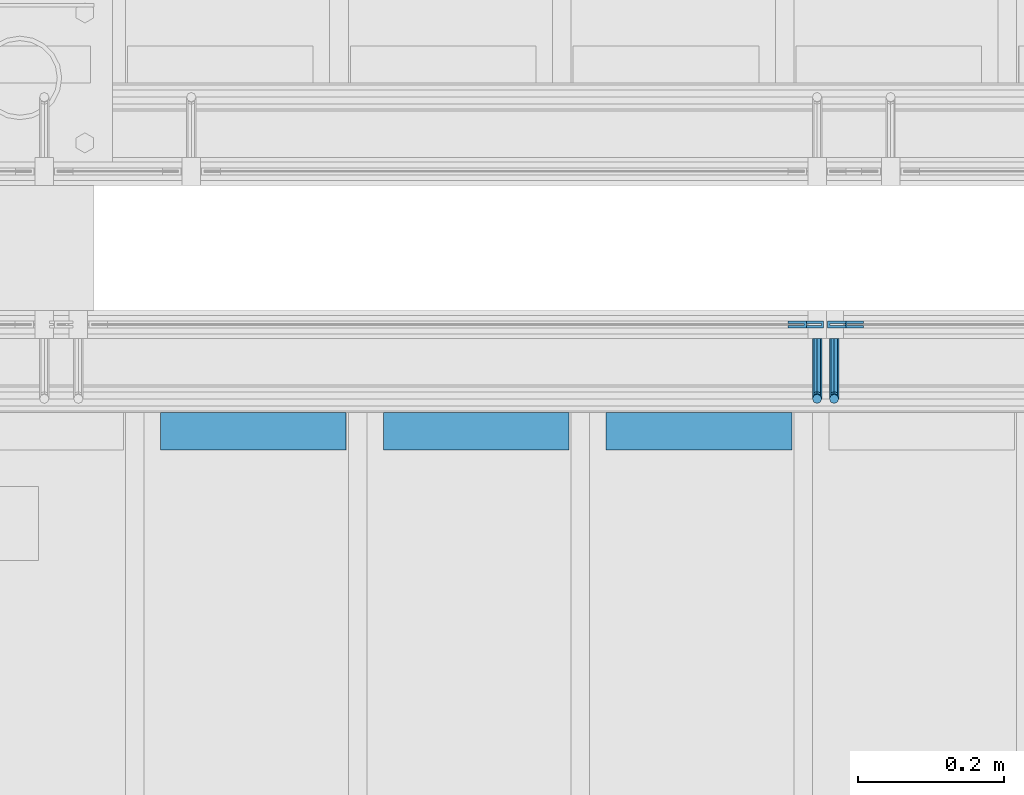
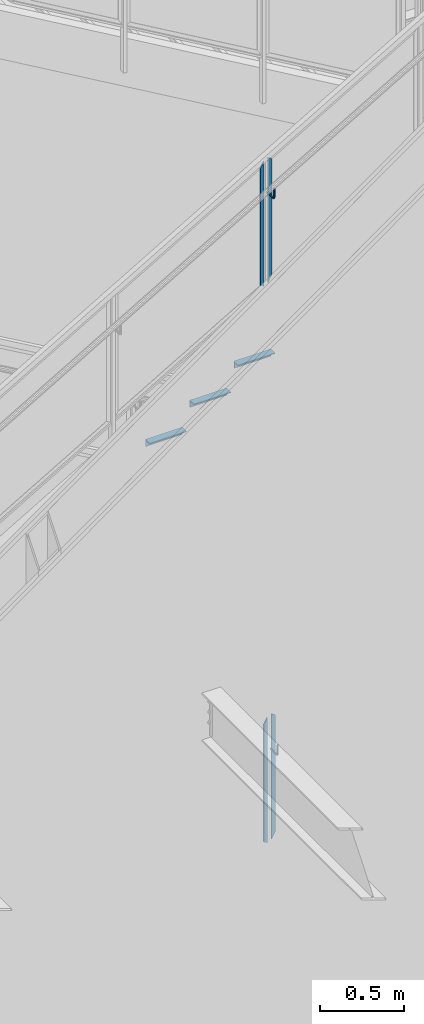
# One storey, part 915 of 1179: 9 beams, 3 elements without a shape of their own.
"""IFC2X3 building model written with IfcOpenShell, lengths in millimetres."""

from ifc_helpers import new_model, si_unit, frame, origin_with_axes, place, context, subcontext, project, spatial, faceted_brep, material, type_object, element, aggregate, save


model = new_model("IFC2X3")

# Units and contexts
model_context = context("Model", 3, precision=1e-05, world=origin_with_axes())
body_context = subcontext(model_context, "Body", "Model", "MODEL_VIEW")
ifc_project = project(units=[si_unit("LENGTHUNIT", "METRE", prefix="MILLI"), si_unit("AREAUNIT", "SQUARE_METRE"), si_unit("VOLUMEUNIT", "CUBIC_METRE"), si_unit("MASSUNIT", "GRAM", prefix="KILO"), si_unit("TIMEUNIT", "SECOND"), si_unit("PLANEANGLEUNIT", "RADIAN"), si_unit("SOLIDANGLEUNIT", "STERADIAN"), si_unit("THERMODYNAMICTEMPERATUREUNIT", "DEGREE_CELSIUS"), si_unit("LUMINOUSINTENSITYUNIT", "LUMEN")], contexts=[model_context])

# Site, building, storey
site_placement = place(None, origin_with_axes())
site = spatial("IfcSite", under=ifc_project, at=site_placement, CompositionType="ELEMENT")
building_placement = place(site_placement, origin_with_axes())
building = spatial("IfcBuilding", under=site, at=building_placement, Name="Undefined", CompositionType="ELEMENT")
storey_placement = place(building_placement, origin_with_axes())
storey = spatial("IfcBuildingStorey", under=building, at=storey_placement, Name="Undefined", CompositionType="ELEMENT", Elevation=0.0)

# Assembly, beams
assembly_1_placement = place(storey_placement, origin_with_axes())
assembly_1 = element("IfcElementAssembly", 1, at=assembly_1_placement, inside=storey, Name="GUARDRAIL", AssemblyPlace="NOTDEFINED", PredefinedType="RIGID_FRAME")
ifc_material_1 = material(Name="STEEL/BUY-OUT")
beam_type_1 = type_object("IfcBeamType", PredefinedType="NOTDEFINED")
beam_1_placement = place(assembly_1_placement, frame((21705.8081529927, 39468.4251646336, 6095.74172723557), z_axis=(0.0, 0.0, -1.0), x_axis=(-1.0, 0.0, 0.0)))
beam_1 = element("IfcBeam", 2, at=beam_1_placement, type_object=beam_type_1, material=ifc_material_1, Name="U-EDGE", context=body_context, shape_type="Brep", body=[
    faceted_brep([(0.0, 1.58750000000146, -439.43612632327), (0.0, -1.58750000000146, -439.43612632327), (0.0, -1.58750000000146, 409.802710675423), (0.0, 1.58750000000146, 409.802710675423), (22.2250000000313, 1.58750000000146, -452.201447879431), (22.2250000000313, 1.58750000000146, 448.497212762225), (22.2250000000313, 4.76249999999709, -452.201447879431), (22.2250000000313, 4.76249999999709, 448.497212762225), (6.54836185276508e-11, 4.76249999999709, -439.436126323308), (6.54836185276508e-11, 4.76249999999709, 409.802710675536), (6.54836185276508e-11, 7.9375, -439.436126323308), (6.54836185276508e-11, 7.9375, 409.802710675536), (25.4000000000342, 7.9375, -454.025), (25.4000000000342, 7.9375, 454.025), (25.4000000000342, -1.58750000000146, -454.025), (25.4000000000342, -1.58750000000146, 454.025)], [[[0, 1, 2, 3]], [[4, 0, 3, 5]], [[6, 4, 5, 7]], [[8, 6, 7, 9]], [[10, 8, 9, 11]], [[12, 10, 11, 13]], [[14, 12, 13, 15]], [[11, 9, 7, 5, 3, 2, 15, 13]], [[1, 14, 15, 2]], [[0, 4, 6, 8, 10, 12, 14, 1]]]),
])
beam_2_placement = place(assembly_1_placement, frame((21626.1698466937, 39468.4251646336, 6078.91951662336), z_axis=(0.0, 0.0, -1.0), x_axis=(1.0, 0.0, 0.0)))
beam_2 = element("IfcBeam", 3, at=beam_2_placement, type_object=beam_type_1, material=ifc_material_1, Name="U-EDGE", context=body_context, shape_type="Brep", body=[
    faceted_brep([(6.54836185276508e-11, -4.76249999999709, -409.802660159926), (6.54836185276508e-11, -7.9375, -409.802660159925), (6.54836185276508e-11, -7.9375, 439.435789033928), (6.54836185276508e-11, -4.76249999999709, 439.435789033928), (22.2250000000313, -4.76249999999709, -448.497207519993), (22.2250000000313, -4.76249999999709, 452.20157845494), (22.2250000000313, -1.58750000000146, -448.497207519993), (22.2250000000313, -1.58750000000146, 452.20157845494), (0.0, -1.58750000000146, -409.802660159811), (0.0, -1.58750000000146, 439.43578903389), (0.0, 1.58750000000146, -409.802660159811), (0.0, 1.58750000000146, 439.43578903389), (25.4000000000342, 1.58750000000146, -454.025), (25.4000000000342, 1.58750000000146, 454.025), (25.4000000000342, -7.9375, -454.025), (25.4000000000342, -7.9375, 454.025)], [[[0, 1, 2, 3]], [[4, 0, 3, 5]], [[6, 4, 5, 7]], [[8, 6, 7, 9]], [[10, 8, 9, 11]], [[12, 10, 11, 13]], [[14, 12, 13, 15]], [[11, 9, 7, 5, 3, 2, 15, 13]], [[1, 14, 15, 2]], [[0, 4, 6, 8, 10, 12, 14, 1]]]),
])

assembly_2_placement = place(storey_placement, origin_with_axes())
assembly_2 = element("IfcElementAssembly", 4, at=assembly_2_placement, inside=storey, Name="GUARDRAIL", AssemblyPlace="NOTDEFINED", PredefinedType="RIGID_FRAME")
beam_3_placement = place(assembly_2_placement, frame((21729.5676338992, 39468.4251653905, 2040.92146211606), z_axis=(0.0, 0.0, -1.0), x_axis=(-1.0, 0.0, 0.0)))
beam_3 = element("IfcBeam", 5, at=beam_3_placement, type_object=beam_type_1, material=ifc_material_1, Name="U-EDGE", context=body_context, shape_type="Brep", body=[
    faceted_brep([(0.0, 1.58750000000146, -439.570271458992), (0.0, -1.58750000000146, -439.570271458992), (0.0, -1.58750000000146, 410.762302941614), (0.0, 1.58750000000146, 410.762302941614), (22.2250000000131, 1.58750000000146, -452.383647202629), (22.2250000000131, 1.58750000000146, 449.311912848919), (22.2250000000131, 4.76249999999709, -452.383647202629), (22.2250000000131, 4.76249999999709, 449.311912848919), (2.91038304567337e-11, 4.76249999999709, -439.570271459009), (2.91038304567337e-11, 4.76249999999709, 410.762303199042), (2.91038304567337e-11, 7.9375, -439.570271459009), (2.91038304567337e-11, 7.9375, 410.762303199042), (25.400000000016, 7.9375, -454.214129451719), (25.3999999999687, 7.9375, 454.819), (25.400000000016, -1.58750000000146, -454.214129451719), (25.3999999999687, -1.58750000000146, 454.819)], [[[0, 1, 2, 3]], [[4, 0, 3, 5]], [[6, 4, 5, 7]], [[8, 6, 7, 9]], [[10, 8, 9, 11]], [[12, 10, 11, 13]], [[14, 12, 13, 15]], [[11, 9, 7, 5, 3, 2, 15, 13]], [[1, 14, 15, 2]], [[0, 4, 6, 8, 10, 12, 14, 1]]]),
])
beam_4_placement = place(assembly_2_placement, frame((21649.7957588991, 39468.4251653905, 2024.1467913869), z_axis=(0.0, 0.0, -1.0), x_axis=(1.0, 0.0, 0.0)))
beam_4 = element("IfcBeam", 6, at=beam_4_placement, type_object=beam_type_1, material=ifc_material_1, Name="U-EDGE", context=body_context, shape_type="Brep", body=[
    faceted_brep([(2.91038304567337e-11, -4.76249999999709, -410.157581087356), (2.91038304567337e-11, -7.9375, -410.157581087356), (2.91038304567337e-11, -7.9375, 440.175143067736), (2.91038304567337e-11, -4.76249999999709, 440.175143067736), (22.2250000000131, -4.76249999999709, -448.707195046795), (22.2250000000131, -4.76249999999709, 452.988518745257), (22.2250000000131, -1.58750000000146, -448.707195046795), (22.2250000000131, -1.58750000000146, 452.988518745257), (0.0, -1.58750000000146, -410.157581087306), (0.0, -1.58750000000146, 440.175143067719), (0.0, 1.58750000000146, -410.157581087305), (0.0, 1.58750000000146, 440.175143067719), (25.400000000016, 1.58750000000146, -454.21428275529), (25.400000000016, 1.58750000000146, 454.819), (25.400000000016, -7.9375, -454.21428275529), (25.400000000016, -7.9375, 454.819)], [[[0, 1, 2, 3]], [[4, 0, 3, 5]], [[6, 4, 5, 7]], [[8, 6, 7, 9]], [[10, 8, 9, 11]], [[12, 10, 11, 13]], [[14, 12, 13, 15]], [[11, 9, 7, 5, 3, 2, 15, 13]], [[1, 14, 15, 2]], [[0, 4, 6, 8, 10, 12, 14, 1]]]),
])

assembly_3_placement = place(storey_placement, origin_with_axes())
assembly_3 = element("IfcElementAssembly", 7, at=assembly_3_placement, inside=storey, Name="STAIR", AssemblyPlace="NOTDEFINED", PredefinedType="RIGID_FRAME")
ifc_material_2 = material(Name="STEEL/A36")
beam_type_2 = type_object("IfcBeamType", Name="L2X2X3/16", PredefinedType="NOTDEFINED")
beam_5_placement = place(assembly_3_placement, frame((21377.6130334773, 39325.5499999802, 5223.47030000019), z_axis=(0.0, -1.0, 0.0), x_axis=(1.0, 0.0, 0.0)))
beam_5 = element("IfcBeam", 8, at=beam_5_placement, type_object=beam_type_2, material=ifc_material_2, Name="ANGLE", ObjectType="L2X2X3/16", context=body_context, shape_type="Brep", body=[
    faceted_brep([(0.0, 25.3999999999996, -25.4000000000015), (0.0, 25.3999999999996, 25.4000000000015), (254.0, 25.3999999999996, 25.4000000000001), (254.0, 25.3999999999996, -25.4000000000001), (0.0, 20.6374999999998, 25.4000000000015), (254.0, 20.6374999999998, 25.4000000000001), (0.0, 20.6374999999998, -20.6374999999971), (254.0, 20.6374999999998, -20.6374999999998), (0.0, -25.3999999999996, -20.6374999999971), (254.0, -25.3999999999996, -20.6374999999998), (0.0, -25.3999999999996, -25.4000000000015), (254.0, -25.3999999999996, -25.4000000000001)], [[[0, 1, 2, 3]], [[1, 4, 5, 2]], [[4, 6, 7, 5]], [[6, 8, 9, 7]], [[8, 10, 11, 9]], [[10, 0, 3, 11]], [[5, 7, 9, 11, 3, 2]], [[10, 8, 6, 4, 1, 0]]]),
])
beam_6_placement = place(assembly_3_placement, frame((21072.8130335002, 39325.5499999802, 5045.67030000019), z_axis=(0.0, -1.0, 0.0), x_axis=(1.0, 0.0, 0.0)))
beam_6 = element("IfcBeam", 9, at=beam_6_placement, type_object=beam_type_2, material=ifc_material_2, Name="ANGLE", ObjectType="L2X2X3/16", context=body_context, shape_type="Brep", body=[
    faceted_brep([(0.0, 25.3999999999996, -25.4000000000015), (0.0, 25.3999999999996, 25.4000000000015), (254.0, 25.3999999999996, 25.4000000000001), (254.0, 25.3999999999996, -25.4000000000001), (0.0, 20.6374999999998, 25.4000000000015), (254.0, 20.6374999999998, 25.4000000000001), (0.0, 20.6374999999998, -20.6374999999971), (254.0, 20.6374999999998, -20.6374999999998), (0.0, -25.3999999999996, -20.6374999999971), (254.0, -25.3999999999996, -20.6374999999998), (0.0, -25.3999999999996, -25.4000000000015), (254.0, -25.3999999999996, -25.4000000000001)], [[[0, 1, 2, 3]], [[1, 4, 5, 2]], [[4, 6, 7, 5]], [[6, 8, 9, 7]], [[8, 10, 11, 9]], [[10, 0, 3, 11]], [[5, 7, 9, 11, 3, 2]], [[10, 8, 6, 4, 1, 0]]]),
])
beam_7_placement = place(assembly_3_placement, frame((20768.0130335231, 39325.5499999802, 4867.87030000019), z_axis=(0.0, -1.0, 0.0), x_axis=(1.0, 0.0, 0.0)))
beam_7 = element("IfcBeam", 10, at=beam_7_placement, type_object=beam_type_2, material=ifc_material_2, Name="ANGLE", ObjectType="L2X2X3/16", context=body_context, shape_type="Brep", body=[
    faceted_brep([(0.0, 25.3999999999996, -25.4000000000015), (0.0, 25.3999999999996, 25.4000000000015), (254.0, 25.3999999999996, 25.4000000000001), (254.0, 25.3999999999996, -25.4000000000001), (0.0, 20.6374999999998, 25.4000000000015), (254.0, 20.6374999999998, 25.4000000000001), (0.0, 20.6374999999998, -20.6374999999971), (254.0, 20.6374999999998, -20.6374999999998), (0.0, -25.3999999999996, -20.6374999999971), (254.0, -25.3999999999996, -20.6374999999998), (0.0, -25.3999999999996, -25.4000000000015), (254.0, -25.3999999999996, -25.4000000000001)], [[[0, 1, 2, 3]], [[1, 4, 5, 2]], [[4, 6, 7, 5]], [[6, 8, 9, 7]], [[8, 10, 11, 9]], [[10, 0, 3, 11]], [[5, 7, 9, 11, 3, 2]], [[10, 8, 6, 4, 1, 0]]]),
])
aggregate(assembly_3, [beam_5, beam_6, beam_7])

# Beam
beam_type_3 = type_object("IfcBeamType", PredefinedType="NOTDEFINED")
beam_8_placement = place(assembly_1_placement, frame((21666.200000343, 39452.5499992245, 6314.71658083848), z_axis=(0.0, 0.0, 1.0), x_axis=(0.0, -1.0, 0.0)))
beam_8 = element("IfcBeam", 11, at=beam_8_placement, type_object=beam_type_3, material=ifc_material_2, Name="BRACKET", context=body_context, shape_type="Brep", body=[
    faceted_brep([(0.0, 0.0, 6.34999999999991), (0.0, -4.49012806053361, 4.49012806053452), (69.849999425729, -4.49012806053361, 4.49012806053452), (69.849999425729, 0.0, 6.34999999999991), (0.0, 4.49012806053361, 4.49012806053452), (69.849999425729, 4.49012806053361, 4.49012806053452), (0.0, 6.34999999999854, 0.0), (69.849999425729, 6.34999999999854, 0.0), (0.0, 4.49012806053361, -4.49012806053452), (69.849999425729, 4.49012806053361, -4.49012806053452), (0.0, 0.0, -6.34999999999991), (69.849999425729, 0.0, -6.34999999999991), (0.0, -4.49012806053361, -4.49012806053452), (69.849999425729, -4.49012806053361, -4.49012806053452), (0.0, -6.34999999999854, 0.0), (69.849999425729, -6.34999999999854, 0.0), (76.1999993303689, -6.34999999999854, 1.70147734638658), (73.9549353000984, -4.49012806053361, 5.59004231305425), (73.024999330366, 0.0, 7.20073866041639), (73.9549353000984, 4.49012806053361, 5.59004231305425), (76.1999993303689, 6.34999999999854, 1.70147734638658), (78.445063360632, 4.49012806053361, -2.18708762028064), (79.3749993303718, 0.0, -3.79778396764323), (78.445063360632, -4.49012806053361, -2.18708762028064), (84.7370868552753, 4.49012806053361, 4.10493587436031), (87.0401272955278, 4.49012806053361, 12.6999998092651), (88.8999992349927, 0.0, 12.6999998092651), (86.3477832026401, 0.0, 3.17499990462693), (80.8485218886053, 6.34999999999854, 6.34999990462893), (82.5499992349942, 6.34999999999854, 12.6999998092651), (76.9599569219426, 4.49012806053361, 8.59506393489755), (78.0598711744606, 4.49012806053361, 12.6999998092651), (75.3492605745778, 0.0, 9.52499990463093), (76.1999992349956, 0.0, 12.6999998092651), (76.9599569219426, -4.49012806053361, 8.59506393489755), (78.0598711744606, -4.49012806053361, 12.6999998092651), (80.8485218886053, -6.34999999999854, 6.34999990462893), (82.5499992349942, -6.34999999999854, 12.6999998092651), (84.7370868552753, -4.49012806053361, 4.10493587436031), (87.0401272955278, -4.49012806053361, 12.6999998092651), (88.8999992349927, 0.0, 76.2000000000003), (87.0401280961523, -4.4901280621234, 73.5807586148453), (82.5500000355751, -6.35000000147556, 72.4958333104305), (78.0598719750778, -4.4901280619415, 73.5807586149517), (76.1999992349956, 0.0, 76.2000000000003), (78.0598719752597, 4.49012805902021, 78.8192413833694), (82.550000035837, 6.34999999837237, 79.9041666931562), (87.0401280963342, 4.49012805883831, 78.819241383263)], [[[0, 1, 2, 3]], [[4, 0, 3, 5]], [[6, 4, 5, 7]], [[8, 6, 7, 9]], [[10, 8, 9, 11]], [[12, 10, 11, 13]], [[1, 0, 4, 6, 8, 10, 12, 14]], [[1, 14, 15, 2]], [[14, 12, 13, 15]], [[2, 15, 16, 17]], [[3, 2, 17, 18]], [[5, 3, 18, 19]], [[7, 5, 19, 20]], [[9, 7, 20, 21]], [[11, 9, 21, 22]], [[13, 11, 22, 23]], [[24, 25, 26, 27]], [[28, 29, 25, 24]], [[30, 31, 29, 28]], [[32, 33, 31, 30]], [[34, 35, 33, 32]], [[36, 37, 35, 34]], [[38, 39, 37, 36]], [[27, 26, 39, 38]], [[22, 27, 38, 23]], [[21, 24, 27, 22]], [[20, 28, 24, 21]], [[19, 30, 28, 20]], [[18, 32, 30, 19]], [[17, 34, 32, 18]], [[16, 36, 34, 17]], [[23, 38, 36, 16]], [[15, 13, 23, 16]], [[39, 26, 40, 41]], [[37, 39, 41, 42]], [[35, 37, 42, 43]], [[33, 35, 43, 44]], [[31, 33, 44, 45]], [[29, 31, 45, 46]], [[25, 29, 46, 47]], [[26, 25, 47, 40]], [[46, 45, 44, 43, 42, 41, 40, 47]]]),
])

aggregate(assembly_1, [beam_8, beam_1, beam_2])

beam_9_placement = place(assembly_2_placement, frame((21689.4832588991, 39452.5499999814, 2259.86783206134), z_axis=(0.0, 0.0, 1.0), x_axis=(0.0, -1.0, 0.0)))
beam_9 = element("IfcBeam", 12, at=beam_9_placement, type_object=beam_type_3, material=ifc_material_2, Name="BRACKET", context=body_context, shape_type="Brep", body=[
    faceted_brep([(0.0, 0.0, 6.34999999999991), (0.0, -4.49012806053361, 4.49012806053452), (69.849999425729, -4.49012806053361, 4.49012806053452), (69.849999425729, 0.0, 6.34999999999991), (0.0, 4.49012806053361, 4.49012806053452), (69.849999425729, 4.49012806053361, 4.49012806053452), (0.0, 6.34999999999854, 0.0), (69.849999425729, 6.34999999999854, 0.0), (0.0, 4.49012806053361, -4.49012806053452), (69.849999425729, 4.49012806053361, -4.49012806053452), (0.0, 0.0, -6.34999999999991), (69.849999425729, 0.0, -6.34999999999991), (0.0, -4.49012806053361, -4.49012806053452), (69.849999425729, -4.49012806053361, -4.49012806053452), (0.0, -6.34999999999854, 0.0), (69.849999425729, -6.34999999999854, 0.0), (76.1999993303689, -6.34999999999854, 1.70147734638658), (73.9549353000984, -4.49012806053361, 5.59004231305425), (73.024999330366, 0.0, 7.20073866041639), (73.9549353000984, 4.49012806053361, 5.59004231305425), (76.1999993303689, 6.34999999999854, 1.70147734638658), (78.445063360632, 4.49012806053361, -2.18708762028064), (79.3749993303718, 0.0, -3.79778396764323), (78.445063360632, -4.49012806053361, -2.18708762028064), (84.7370868552753, 4.49012806053361, 4.10493587436031), (87.0401272955278, 4.49012806053361, 12.6999998092651), (88.8999992349927, 0.0, 12.6999998092651), (86.3477832026401, 0.0, 3.17499990462693), (80.8485218886053, 6.34999999999854, 6.34999990462893), (82.5499992349942, 6.34999999999854, 12.6999998092651), (76.9599569219426, 4.49012806053361, 8.59506393489755), (78.0598711744606, 4.49012806053361, 12.6999998092651), (75.3492605745778, 0.0, 9.52499990463093), (76.1999992349956, 0.0, 12.6999998092651), (76.9599569219426, -4.49012806053361, 8.59506393489755), (78.0598711744606, -4.49012806053361, 12.6999998092651), (80.8485218886053, -6.34999999999854, 6.34999990462893), (82.5499992349942, -6.34999999999854, 12.6999998092651), (84.7370868552753, -4.49012806053361, 4.10493587436031), (87.0401272955278, -4.49012806053361, 12.6999998092651), (88.8999992349927, 0.0, 76.2000000000003), (87.0401280961523, -4.4901280621234, 73.5807586148453), (82.5500000355751, -6.35000000147556, 72.4958333104305), (78.0598719750778, -4.4901280619415, 73.5807586149517), (76.1999992349956, 0.0, 76.2000000000003), (78.0598719752597, 4.49012805902021, 78.8192413833694), (82.550000035837, 6.34999999837237, 79.9041666931562), (87.0401280963342, 4.49012805883831, 78.819241383263)], [[[0, 1, 2, 3]], [[4, 0, 3, 5]], [[6, 4, 5, 7]], [[8, 6, 7, 9]], [[10, 8, 9, 11]], [[12, 10, 11, 13]], [[1, 0, 4, 6, 8, 10, 12, 14]], [[1, 14, 15, 2]], [[14, 12, 13, 15]], [[2, 15, 16, 17]], [[3, 2, 17, 18]], [[5, 3, 18, 19]], [[7, 5, 19, 20]], [[9, 7, 20, 21]], [[11, 9, 21, 22]], [[13, 11, 22, 23]], [[24, 25, 26, 27]], [[28, 29, 25, 24]], [[30, 31, 29, 28]], [[32, 33, 31, 30]], [[34, 35, 33, 32]], [[36, 37, 35, 34]], [[38, 39, 37, 36]], [[27, 26, 39, 38]], [[22, 27, 38, 23]], [[21, 24, 27, 22]], [[20, 28, 24, 21]], [[19, 30, 28, 20]], [[18, 32, 30, 19]], [[17, 34, 32, 18]], [[16, 36, 34, 17]], [[23, 38, 36, 16]], [[15, 13, 23, 16]], [[39, 26, 40, 41]], [[37, 39, 41, 42]], [[35, 37, 42, 43]], [[33, 35, 43, 44]], [[31, 33, 44, 45]], [[29, 31, 45, 46]], [[25, 29, 46, 47]], [[26, 25, 47, 40]], [[46, 45, 44, 43, 42, 41, 40, 47]]]),
])

aggregate(assembly_2, [beam_9, beam_3, beam_4])

save(model, "model.ifc")
